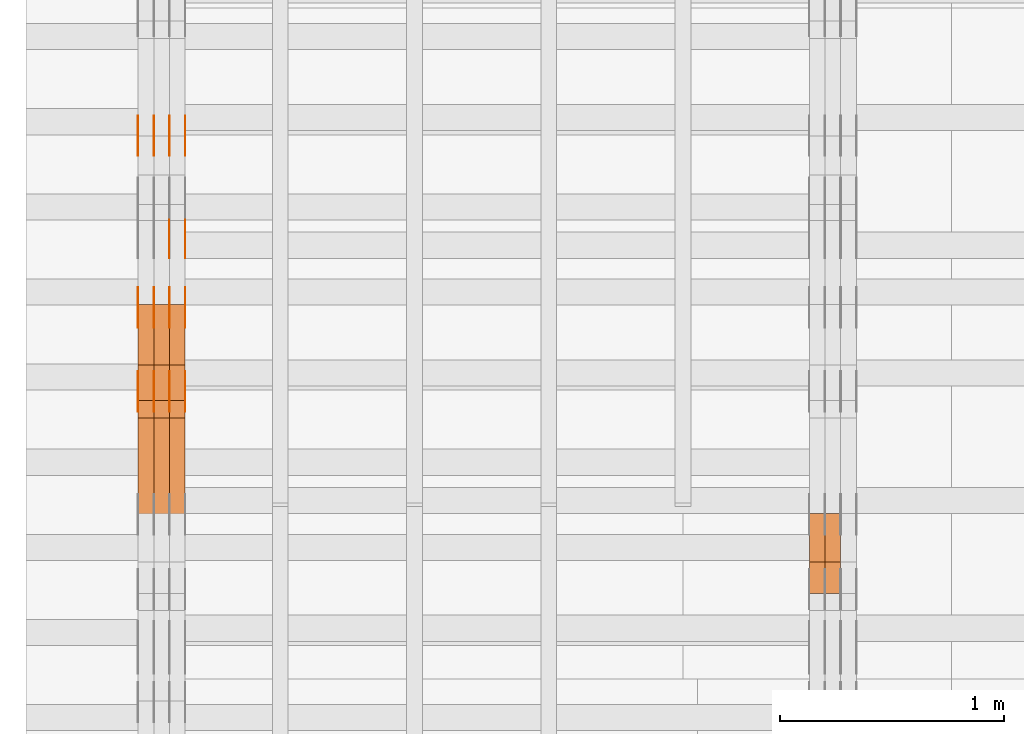
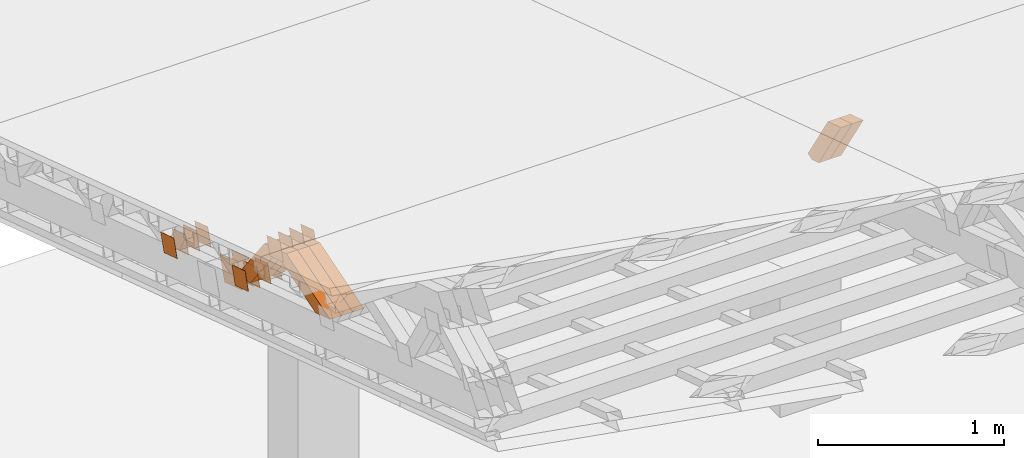
# One storey, part 174 of 385: 28 proxies.
"""IFC2X3 building model written with IfcOpenShell, lengths in millimetres."""

from ifc_helpers import new_model, entity, si_unit, converted_unit, derived_unit, direction, frame, origin, place, context, subcontext, project, spatial, polyline, outline, extrude, source, transform, mapped, material, type_object, type_shapes, element, save


model = new_model("IFC2X3")

# Units and contexts
model_context = context("Model", 3, precision=0.01, world=origin(), true_north=direction((6.12303176911189e-17, 1.0)))
body_context = subcontext(model_context, "Body", "Model", "MODEL_VIEW")
ifc_project = project(units=[si_unit("LENGTHUNIT", "METRE", prefix="MILLI"), si_unit("AREAUNIT", "SQUARE_METRE"), si_unit("VOLUMEUNIT", "CUBIC_METRE"), converted_unit("PLANEANGLEUNIT", "DEGREE", entity("IfcRatioMeasure", 0.0174532925199433), si_unit("PLANEANGLEUNIT", "RADIAN"), dimensions=[0, 0, 0, 0, 0, 0, 0]), si_unit("MASSUNIT", "GRAM", prefix="KILO"), derived_unit("MASSDENSITYUNIT", [(si_unit("MASSUNIT", "GRAM", prefix="KILO"), 1), (si_unit("LENGTHUNIT", "METRE"), -3)]), si_unit("TIMEUNIT", "SECOND"), si_unit("FREQUENCYUNIT", "HERTZ"), si_unit("THERMODYNAMICTEMPERATUREUNIT", "DEGREE_CELSIUS"), derived_unit("THERMALTRANSMITTANCEUNIT", [(si_unit("MASSUNIT", "GRAM", prefix="KILO"), 1), (si_unit("THERMODYNAMICTEMPERATUREUNIT", "KELVIN"), -1), (si_unit("TIMEUNIT", "SECOND"), -3)]), derived_unit("VOLUMETRICFLOWRATEUNIT", [(si_unit("LENGTHUNIT", "METRE"), 3), (si_unit("TIMEUNIT", "SECOND"), -1)]), si_unit("ELECTRICCURRENTUNIT", "AMPERE"), si_unit("ELECTRICVOLTAGEUNIT", "VOLT"), si_unit("POWERUNIT", "WATT"), si_unit("FORCEUNIT", "NEWTON", prefix="KILO"), si_unit("ILLUMINANCEUNIT", "LUX"), si_unit("LUMINOUSFLUXUNIT", "LUMEN"), si_unit("LUMINOUSINTENSITYUNIT", "CANDELA"), derived_unit("USERDEFINED", [(si_unit("MASSUNIT", "GRAM", prefix="KILO"), -1), (si_unit("LENGTHUNIT", "METRE"), -2), (si_unit("TIMEUNIT", "SECOND"), 3), (si_unit("LUMINOUSFLUXUNIT", "LUMEN"), 1)]), derived_unit("LINEARVELOCITYUNIT", [(si_unit("LENGTHUNIT", "METRE"), 1), (si_unit("TIMEUNIT", "SECOND"), -1)]), si_unit("PRESSUREUNIT", "PASCAL"), derived_unit("USERDEFINED", [(si_unit("LENGTHUNIT", "METRE"), -2), (si_unit("MASSUNIT", "GRAM", prefix="KILO"), 1), (si_unit("TIMEUNIT", "SECOND"), -2)])], contexts=[model_context])

# Site, building, storey
site_placement = place(None, origin())
site = spatial("IfcSite", under=ifc_project, at=site_placement, CompositionType="ELEMENT")
building_placement = place(site_placement, origin())
building = spatial("IfcBuilding", under=site, at=building_placement, CompositionType="ELEMENT")
storey_placement = place(building_placement, origin())
storey = spatial("IfcBuildingStorey", under=building, at=storey_placement, Name="Default", CompositionType="ELEMENT", Elevation=0.0)

# Proxies
ifc_material_1 = material(Name="IfcSurfaceStyle #48216")
building_element_proxy_type_1 = type_object("IfcBuildingElementProxyType", Name="T1-W29 48214", PredefinedType="NOTDEFINED", material=ifc_material_1)
shared_shape_1 = source(origin(), body_context, "Body", "SweptSolid", [
    extrude(outline(polyline([(-202.325994317059, -47.5000867467013), (200.714255560873, -47.5000867467013), (187.834128885383, 0.000593513395139059), (130.590899902046, 47.4997899900038), (-316.813290031243, 47.4997899900038), (-202.325994317059, -47.5000867467013)])), frame((200.714255560873, 47.5001935424745, 0.0), z_axis=(0.0, 0.0, 1.0), x_axis=(-1.0, 0.0, 0.0)), (0.0, 0.0, 1.0), 70.0),
])
type_shapes(building_element_proxy_type_1, [shared_shape_1])
proxy_1_placement = place(building_placement, frame((3315.0, 20827.0771193222, 1890.72342063252), z_axis=(-1.0, 0.0, 0.0), x_axis=(0.0, -0.534567451138397, 0.845125813227473)))
element("IfcBuildingElementProxy", 1, at=proxy_1_placement, inside=storey, type_object=building_element_proxy_type_1, material=ifc_material_1, Name="T1-W29", context=body_context, shape_type="MappedRepresentation", body=[
    mapped(shared_shape_1, transform((0.0, 0.0, 0.0), scale=1.0)),
])
ifc_material_2 = material(Name="IfcSurfaceStyle #48150")
building_element_proxy_type_2 = type_object("IfcBuildingElementProxyType", Name="T1-W29 48148", PredefinedType="NOTDEFINED", material=ifc_material_2)
shared_shape_2 = source(origin(), body_context, "Body", "SweptSolid", [
    extrude(outline(polyline([(-202.325994317059, -47.5000867467013), (200.714255560873, -47.5000867467013), (187.834128885383, 0.000593513395139059), (130.590899902046, 47.4997899900038), (-316.813290031243, 47.4997899900038), (-202.325994317059, -47.5000867467013)])), frame((200.714255560873, 47.5001935424745, 0.0), z_axis=(0.0, 0.0, 1.0), x_axis=(-1.0, 0.0, 0.0)), (0.0, 0.0, 1.0), 70.0),
])
type_shapes(building_element_proxy_type_2, [shared_shape_2])
proxy_2_placement = place(building_placement, frame((3245.0, 20827.0771193222, 1890.72342063252), z_axis=(-1.0, 0.0, 0.0), x_axis=(0.0, -0.534567451138397, 0.845125813227473)))
element("IfcBuildingElementProxy", 2, at=proxy_2_placement, inside=storey, type_object=building_element_proxy_type_2, material=ifc_material_2, Name="T1-W29", context=body_context, shape_type="MappedRepresentation", body=[
    mapped(shared_shape_2, transform((0.0, 0.0, 0.0), scale=1.0)),
])
ifc_material_3 = material(Name="IfcSurfaceStyle #34244")
building_element_proxy_type_3 = type_object("IfcBuildingElementProxyType", PredefinedType="NOTDEFINED", material=ifc_material_3)
shared_shape_3 = source(origin(), body_context, "Body", "SweptSolid", [
    extrude(outline(polyline([(-74.9998794200123, -59.999984515643), (74.9998565677174, -59.999984515643), (74.9998794200123, 59.999984515643), (-74.9998565677174, 59.999984515643), (-74.9998794200123, -59.999984515643)])), frame((75.0000769557496, 60.0000596852268, 0.0), z_axis=(0.0, 0.0, 1.0), x_axis=(-1.0, 0.0, 0.0)), (0.0, 0.0, 1.0), 1.3),
])
type_shapes(building_element_proxy_type_3, [shared_shape_3])
proxy_3_placement = place(building_placement, frame((386.299999999986, 22649.3668870864, 1282.62115477841), z_axis=(-1.0, 0.0, 0.0), x_axis=(0.0, -0.951056516295124, 0.309016994375039)))
element("IfcBuildingElementProxy", 3, at=proxy_3_placement, inside=storey, type_object=building_element_proxy_type_3, material=ifc_material_3, context=body_context, shape_type="MappedRepresentation", body=[
    mapped(shared_shape_3, transform((0.0, 0.0, 0.0), scale=1.0)),
])
ifc_material_4 = material(Name="IfcSurfaceStyle #34187")
building_element_proxy_type_4 = type_object("IfcBuildingElementProxyType", PredefinedType="NOTDEFINED", material=ifc_material_4)
shared_shape_4 = source(origin(), body_context, "Body", "SweptSolid", [
    extrude(outline(polyline([(-74.9998794200123, -59.999984515643), (74.9998565677174, -59.999984515643), (74.9998794200123, 59.999984515643), (-74.9998565677174, 59.999984515643), (-74.9998794200123, -59.999984515643)])), frame((75.0000769557496, 60.0000596852268, 0.0), z_axis=(0.0, 0.0, 1.0), x_axis=(-1.0, 0.0, 0.0)), (0.0, 0.0, 1.0), 1.3),
])
type_shapes(building_element_proxy_type_4, [shared_shape_4])
proxy_4_placement = place(building_placement, frame((315.0, 22649.3668870864, 1282.62115477841), z_axis=(-1.0, 0.0, 0.0), x_axis=(0.0, -0.951056516295124, 0.309016994375039)))
element("IfcBuildingElementProxy", 4, at=proxy_4_placement, inside=storey, type_object=building_element_proxy_type_4, material=ifc_material_4, context=body_context, shape_type="MappedRepresentation", body=[
    mapped(shared_shape_4, transform((0.0, 0.0, 0.0), scale=1.0)),
])
ifc_material_5 = material(Name="IfcSurfaceStyle #34130")
building_element_proxy_type_5 = type_object("IfcBuildingElementProxyType", PredefinedType="NOTDEFINED", material=ifc_material_5)
shared_shape_5 = source(origin(), body_context, "Body", "SweptSolid", [
    extrude(outline(polyline([(-74.9998794200123, -59.999984515643), (74.9998565677174, -59.999984515643), (74.9998794200123, 59.999984515643), (-74.9998565677174, 59.999984515643), (-74.9998794200123, -59.999984515643)])), frame((75.0000769557496, 60.0000596852268, 0.0), z_axis=(0.0, 0.0, 1.0), x_axis=(-1.0, 0.0, 0.0)), (0.0, 0.0, 1.0), 1.3),
])
type_shapes(building_element_proxy_type_5, [shared_shape_5])
proxy_5_placement = place(building_placement, frame((316.299999999986, 22649.3668870864, 1282.62115477841), z_axis=(-1.0, 0.0, 0.0), x_axis=(0.0, -0.951056516295124, 0.309016994375039)))
element("IfcBuildingElementProxy", 5, at=proxy_5_placement, inside=storey, type_object=building_element_proxy_type_5, material=ifc_material_5, context=body_context, shape_type="MappedRepresentation", body=[
    mapped(shared_shape_5, transform((0.0, 0.0, 0.0), scale=1.0)),
])
ifc_material_6 = material(Name="IfcSurfaceStyle #34073")
building_element_proxy_type_6 = type_object("IfcBuildingElementProxyType", PredefinedType="NOTDEFINED", material=ifc_material_6)
shared_shape_6 = source(origin(), body_context, "Body", "SweptSolid", [
    extrude(outline(polyline([(-74.9998794200123, -59.999984515643), (74.9998565677174, -59.999984515643), (74.9998794200123, 59.999984515643), (-74.9998565677174, 59.999984515643), (-74.9998794200123, -59.999984515643)])), frame((75.0000769557496, 60.0000596852268, 0.0), z_axis=(0.0, 0.0, 1.0), x_axis=(-1.0, 0.0, 0.0)), (0.0, 0.0, 1.0), 1.29999999999999),
])
type_shapes(building_element_proxy_type_6, [shared_shape_6])
proxy_6_placement = place(building_placement, frame((245.0, 22649.3668870864, 1282.62115477841), z_axis=(-1.0, 0.0, 0.0), x_axis=(0.0, -0.951056516295124, 0.309016994375039)))
element("IfcBuildingElementProxy", 6, at=proxy_6_placement, inside=storey, type_object=building_element_proxy_type_6, material=ifc_material_6, context=body_context, shape_type="MappedRepresentation", body=[
    mapped(shared_shape_6, transform((0.0, 0.0, 0.0), scale=1.0)),
])
ifc_material_7 = material(Name="IfcSurfaceStyle #34016")
building_element_proxy_type_7 = type_object("IfcBuildingElementProxyType", PredefinedType="NOTDEFINED", material=ifc_material_7)
shared_shape_7 = source(origin(), body_context, "Body", "SweptSolid", [
    extrude(outline(polyline([(-74.9998794200123, -59.999984515643), (74.9998565677174, -59.999984515643), (74.9998794200123, 59.999984515643), (-74.9998565677174, 59.999984515643), (-74.9998794200123, -59.999984515643)])), frame((75.0000769557496, 60.0000596852268, 0.0), z_axis=(0.0, 0.0, 1.0), x_axis=(-1.0, 0.0, 0.0)), (0.0, 0.0, 1.0), 1.29999999999999),
])
type_shapes(building_element_proxy_type_7, [shared_shape_7])
proxy_7_placement = place(building_placement, frame((246.299999999986, 22649.3668870864, 1282.62115477841), z_axis=(-1.0, 0.0, 0.0), x_axis=(0.0, -0.951056516295124, 0.309016994375039)))
element("IfcBuildingElementProxy", 7, at=proxy_7_placement, inside=storey, type_object=building_element_proxy_type_7, material=ifc_material_7, context=body_context, shape_type="MappedRepresentation", body=[
    mapped(shared_shape_7, transform((0.0, 0.0, 0.0), scale=1.0)),
])
ifc_material_8 = material(Name="IfcSurfaceStyle #33959")
building_element_proxy_type_8 = type_object("IfcBuildingElementProxyType", PredefinedType="NOTDEFINED", material=ifc_material_8)
shared_shape_8 = source(origin(), body_context, "Body", "SweptSolid", [
    extrude(outline(polyline([(-74.9998794200123, -59.999984515643), (74.9998565677174, -59.999984515643), (74.9998794200123, 59.999984515643), (-74.9998565677174, 59.999984515643), (-74.9998794200123, -59.999984515643)])), frame((75.0000769557496, 60.0000596852268, 0.0), z_axis=(0.0, 0.0, 1.0), x_axis=(-1.0, 0.0, 0.0)), (0.0, 0.0, 1.0), 1.29999999999999),
])
type_shapes(building_element_proxy_type_8, [shared_shape_8])
proxy_8_placement = place(building_placement, frame((175.0, 22649.3668870864, 1282.62115477841), z_axis=(-1.0, 0.0, 0.0), x_axis=(0.0, -0.951056516295124, 0.309016994375039)))
element("IfcBuildingElementProxy", 8, at=proxy_8_placement, inside=storey, type_object=building_element_proxy_type_8, material=ifc_material_8, context=body_context, shape_type="MappedRepresentation", body=[
    mapped(shared_shape_8, transform((0.0, 0.0, 0.0), scale=1.0)),
])
ifc_material_9 = material(Name="IfcSurfaceStyle #33560")
building_element_proxy_type_9 = type_object("IfcBuildingElementProxyType", PredefinedType="NOTDEFINED", material=ifc_material_9)
shared_shape_9 = source(origin(), body_context, "Body", "SweptSolid", [
    extrude(outline(polyline([(-99.9999579276585, -84.0000593595837), (100.000141865112, -84.0000593595837), (99.9999579276589, 84.0000593595837), (-100.000141865112, 84.0000593595837), (-99.9999579276585, -84.0000593595837)])), frame((100.000141865112, 84.0000593595837, 0.0), z_axis=(0.0, 0.0, 1.0), x_axis=(-1.0, 0.0, 0.0)), (0.0, 0.0, 1.0), 1.3),
])
type_shapes(building_element_proxy_type_9, [shared_shape_9])
proxy_9_placement = place(building_placement, frame((386.299999999986, 22239.7296395088, 1287.96775368191), z_axis=(-1.0, 0.0, 0.0), x_axis=(0.0, -0.951056516295124, 0.309016994375039)))
element("IfcBuildingElementProxy", 9, at=proxy_9_placement, inside=storey, type_object=building_element_proxy_type_9, material=ifc_material_9, context=body_context, shape_type="MappedRepresentation", body=[
    mapped(shared_shape_9, transform((0.0, 0.0, 0.0), scale=1.0)),
])
ifc_material_10 = material(Name="IfcSurfaceStyle #33503")
building_element_proxy_type_10 = type_object("IfcBuildingElementProxyType", PredefinedType="NOTDEFINED", material=ifc_material_10)
shared_shape_10 = source(origin(), body_context, "Body", "SweptSolid", [
    extrude(outline(polyline([(-99.9999579276585, -84.0000593595837), (100.000141865112, -84.0000593595837), (99.9999579276589, 84.0000593595837), (-100.000141865112, 84.0000593595837), (-99.9999579276585, -84.0000593595837)])), frame((100.000141865112, 84.0000593595837, 0.0), z_axis=(0.0, 0.0, 1.0), x_axis=(-1.0, 0.0, 0.0)), (0.0, 0.0, 1.0), 1.3),
])
type_shapes(building_element_proxy_type_10, [shared_shape_10])
proxy_10_placement = place(building_placement, frame((315.0, 22239.7296395088, 1287.96775368191), z_axis=(-1.0, 0.0, 0.0), x_axis=(0.0, -0.951056516295124, 0.309016994375039)))
element("IfcBuildingElementProxy", 10, at=proxy_10_placement, inside=storey, type_object=building_element_proxy_type_10, material=ifc_material_10, context=body_context, shape_type="MappedRepresentation", body=[
    mapped(shared_shape_10, transform((0.0, 0.0, 0.0), scale=1.0)),
])
ifc_material_11 = material(Name="IfcSurfaceStyle #31166")
building_element_proxy_type_11 = type_object("IfcBuildingElementProxyType", PredefinedType="NOTDEFINED", material=ifc_material_11)
shared_shape_11 = source(origin(), body_context, "Body", "SweptSolid", [
    extrude(outline(polyline([(-75.0001116115454, -60.0000599592451), (75.0000887592496, -60.0000599592451), (75.0001116115454, 60.0000599592451), (-75.0000887592496, 60.0000599592451), (-75.0001116115454, -60.0000599592451)])), frame((75.0001116115454, 60.0000599592451, 0.0), z_axis=(0.0, 0.0, 1.0), x_axis=(-1.0, 0.0, 0.0)), (0.0, 0.0, 1.0), 1.3),
])
type_shapes(building_element_proxy_type_11, [shared_shape_11])
proxy_11_placement = place(building_placement, frame((386.299999999986, 21881.0815195707, 1532.2522473242), z_axis=(-1.0, 0.0, 0.0), x_axis=(0.0, -0.951056516295124, 0.309016994375039)))
element("IfcBuildingElementProxy", 11, at=proxy_11_placement, inside=storey, type_object=building_element_proxy_type_11, material=ifc_material_11, context=body_context, shape_type="MappedRepresentation", body=[
    mapped(shared_shape_11, transform((0.0, 0.0, 0.0), scale=1.0)),
])
ifc_material_12 = material(Name="IfcSurfaceStyle #31109")
building_element_proxy_type_12 = type_object("IfcBuildingElementProxyType", PredefinedType="NOTDEFINED", material=ifc_material_12)
shared_shape_12 = source(origin(), body_context, "Body", "SweptSolid", [
    extrude(outline(polyline([(-75.0001116115454, -60.0000599592451), (75.0000887592496, -60.0000599592451), (75.0001116115454, 60.0000599592451), (-75.0000887592496, 60.0000599592451), (-75.0001116115454, -60.0000599592451)])), frame((75.0001116115454, 60.0000599592451, 0.0), z_axis=(0.0, 0.0, 1.0), x_axis=(-1.0, 0.0, 0.0)), (0.0, 0.0, 1.0), 1.3),
])
type_shapes(building_element_proxy_type_12, [shared_shape_12])
proxy_12_placement = place(building_placement, frame((315.0, 21881.0815195707, 1532.2522473242), z_axis=(-1.0, 0.0, 0.0), x_axis=(0.0, -0.951056516295124, 0.309016994375039)))
element("IfcBuildingElementProxy", 12, at=proxy_12_placement, inside=storey, type_object=building_element_proxy_type_12, material=ifc_material_12, context=body_context, shape_type="MappedRepresentation", body=[
    mapped(shared_shape_12, transform((0.0, 0.0, 0.0), scale=1.0)),
])
ifc_material_13 = material(Name="IfcSurfaceStyle #31052")
building_element_proxy_type_13 = type_object("IfcBuildingElementProxyType", PredefinedType="NOTDEFINED", material=ifc_material_13)
shared_shape_13 = source(origin(), body_context, "Body", "SweptSolid", [
    extrude(outline(polyline([(-75.0001116115454, -60.0000599592451), (75.0000887592496, -60.0000599592451), (75.0001116115454, 60.0000599592451), (-75.0000887592496, 60.0000599592451), (-75.0001116115454, -60.0000599592451)])), frame((75.0001116115454, 60.0000599592451, 0.0), z_axis=(0.0, 0.0, 1.0), x_axis=(-1.0, 0.0, 0.0)), (0.0, 0.0, 1.0), 1.3),
])
type_shapes(building_element_proxy_type_13, [shared_shape_13])
proxy_13_placement = place(building_placement, frame((316.299999999986, 21881.0815195707, 1532.2522473242), z_axis=(-1.0, 0.0, 0.0), x_axis=(0.0, -0.951056516295124, 0.309016994375039)))
element("IfcBuildingElementProxy", 13, at=proxy_13_placement, inside=storey, type_object=building_element_proxy_type_13, material=ifc_material_13, context=body_context, shape_type="MappedRepresentation", body=[
    mapped(shared_shape_13, transform((0.0, 0.0, 0.0), scale=1.0)),
])
ifc_material_14 = material(Name="IfcSurfaceStyle #30995")
building_element_proxy_type_14 = type_object("IfcBuildingElementProxyType", PredefinedType="NOTDEFINED", material=ifc_material_14)
shared_shape_14 = source(origin(), body_context, "Body", "SweptSolid", [
    extrude(outline(polyline([(-75.0001116115454, -60.0000599592451), (75.0000887592496, -60.0000599592451), (75.0001116115454, 60.0000599592451), (-75.0000887592496, 60.0000599592451), (-75.0001116115454, -60.0000599592451)])), frame((75.0001116115454, 60.0000599592451, 0.0), z_axis=(0.0, 0.0, 1.0), x_axis=(-1.0, 0.0, 0.0)), (0.0, 0.0, 1.0), 1.29999999999999),
])
type_shapes(building_element_proxy_type_14, [shared_shape_14])
proxy_14_placement = place(building_placement, frame((245.0, 21881.0815195707, 1532.2522473242), z_axis=(-1.0, 0.0, 0.0), x_axis=(0.0, -0.951056516295124, 0.309016994375039)))
element("IfcBuildingElementProxy", 14, at=proxy_14_placement, inside=storey, type_object=building_element_proxy_type_14, material=ifc_material_14, context=body_context, shape_type="MappedRepresentation", body=[
    mapped(shared_shape_14, transform((0.0, 0.0, 0.0), scale=1.0)),
])
ifc_material_15 = material(Name="IfcSurfaceStyle #30938")
building_element_proxy_type_15 = type_object("IfcBuildingElementProxyType", PredefinedType="NOTDEFINED", material=ifc_material_15)
shared_shape_15 = source(origin(), body_context, "Body", "SweptSolid", [
    extrude(outline(polyline([(-75.0001116115454, -60.0000599592451), (75.0000887592496, -60.0000599592451), (75.0001116115454, 60.0000599592451), (-75.0000887592496, 60.0000599592451), (-75.0001116115454, -60.0000599592451)])), frame((75.0001116115454, 60.0000599592451, 0.0), z_axis=(0.0, 0.0, 1.0), x_axis=(-1.0, 0.0, 0.0)), (0.0, 0.0, 1.0), 1.29999999999999),
])
type_shapes(building_element_proxy_type_15, [shared_shape_15])
proxy_15_placement = place(building_placement, frame((246.299999999986, 21881.0815195707, 1532.2522473242), z_axis=(-1.0, 0.0, 0.0), x_axis=(0.0, -0.951056516295124, 0.309016994375039)))
element("IfcBuildingElementProxy", 15, at=proxy_15_placement, inside=storey, type_object=building_element_proxy_type_15, material=ifc_material_15, context=body_context, shape_type="MappedRepresentation", body=[
    mapped(shared_shape_15, transform((0.0, 0.0, 0.0), scale=1.0)),
])
ifc_material_16 = material(Name="IfcSurfaceStyle #30881")
building_element_proxy_type_16 = type_object("IfcBuildingElementProxyType", PredefinedType="NOTDEFINED", material=ifc_material_16)
shared_shape_16 = source(origin(), body_context, "Body", "SweptSolid", [
    extrude(outline(polyline([(-75.0001116115454, -60.0000599592451), (75.0000887592496, -60.0000599592451), (75.0001116115454, 60.0000599592451), (-75.0000887592496, 60.0000599592451), (-75.0001116115454, -60.0000599592451)])), frame((75.0001116115454, 60.0000599592451, 0.0), z_axis=(0.0, 0.0, 1.0), x_axis=(-1.0, 0.0, 0.0)), (0.0, 0.0, 1.0), 1.29999999999999),
])
type_shapes(building_element_proxy_type_16, [shared_shape_16])
proxy_16_placement = place(building_placement, frame((175.0, 21881.0815195707, 1532.2522473242), z_axis=(-1.0, 0.0, 0.0), x_axis=(0.0, -0.951056516295124, 0.309016994375039)))
element("IfcBuildingElementProxy", 16, at=proxy_16_placement, inside=storey, type_object=building_element_proxy_type_16, material=ifc_material_16, context=body_context, shape_type="MappedRepresentation", body=[
    mapped(shared_shape_16, transform((0.0, 0.0, 0.0), scale=1.0)),
])
ifc_material_17 = material(Name="IfcSurfaceStyle #25694")
building_element_proxy_type_17 = type_object("IfcBuildingElementProxyType", PredefinedType="NOTDEFINED", material=ifc_material_17)
shared_shape_17 = source(origin(), body_context, "Body", "SweptSolid", [
    extrude(outline(polyline([(-74.9998794200064, -59.9999845156358), (74.9998565677224, -59.9999845156358), (74.9998794200064, 59.9999845156358), (-74.9998565677224, 59.9999845156358), (-74.9998794200064, -59.9999845156358)])), frame((74.9999765995044, 60.0000596852337, 0.0), z_axis=(0.0, 0.0, 1.0), x_axis=(-1.0, 0.0, 0.0)), (0.0, 0.0, 1.0), 1.3),
])
type_shapes(building_element_proxy_type_17, [shared_shape_17])
proxy_17_placement = place(building_placement, frame((386.299999999986, 21505.9776314857, 1954.5332951652), z_axis=(-1.0, 0.0, 0.0), x_axis=(0.0, -0.951056516295154, 0.309016994374948)))
element("IfcBuildingElementProxy", 17, at=proxy_17_placement, inside=storey, type_object=building_element_proxy_type_17, material=ifc_material_17, context=body_context, shape_type="MappedRepresentation", body=[
    mapped(shared_shape_17, transform((0.0, 0.0, 0.0), scale=1.0)),
])
ifc_material_18 = material(Name="IfcSurfaceStyle #25637")
building_element_proxy_type_18 = type_object("IfcBuildingElementProxyType", PredefinedType="NOTDEFINED", material=ifc_material_18)
shared_shape_18 = source(origin(), body_context, "Body", "SweptSolid", [
    extrude(outline(polyline([(-74.9998794200064, -59.9999845156358), (74.9998565677224, -59.9999845156358), (74.9998794200064, 59.9999845156358), (-74.9998565677224, 59.9999845156358), (-74.9998794200064, -59.9999845156358)])), frame((74.9999765995044, 60.0000596852337, 0.0), z_axis=(0.0, 0.0, 1.0), x_axis=(-1.0, 0.0, 0.0)), (0.0, 0.0, 1.0), 1.3),
])
type_shapes(building_element_proxy_type_18, [shared_shape_18])
proxy_18_placement = place(building_placement, frame((315.0, 21505.9776314857, 1954.5332951652), z_axis=(-1.0, 0.0, 0.0), x_axis=(0.0, -0.951056516295154, 0.309016994374948)))
element("IfcBuildingElementProxy", 18, at=proxy_18_placement, inside=storey, type_object=building_element_proxy_type_18, material=ifc_material_18, context=body_context, shape_type="MappedRepresentation", body=[
    mapped(shared_shape_18, transform((0.0, 0.0, 0.0), scale=1.0)),
])
ifc_material_19 = material(Name="IfcSurfaceStyle #25580")
building_element_proxy_type_19 = type_object("IfcBuildingElementProxyType", PredefinedType="NOTDEFINED", material=ifc_material_19)
shared_shape_19 = source(origin(), body_context, "Body", "SweptSolid", [
    extrude(outline(polyline([(-74.9998794200064, -59.9999845156358), (74.9998565677224, -59.9999845156358), (74.9998794200064, 59.9999845156358), (-74.9998565677224, 59.9999845156358), (-74.9998794200064, -59.9999845156358)])), frame((74.9999765995044, 60.0000596852337, 0.0), z_axis=(0.0, 0.0, 1.0), x_axis=(-1.0, 0.0, 0.0)), (0.0, 0.0, 1.0), 1.3),
])
type_shapes(building_element_proxy_type_19, [shared_shape_19])
proxy_19_placement = place(building_placement, frame((316.299999999986, 21505.9776314857, 1954.5332951652), z_axis=(-1.0, 0.0, 0.0), x_axis=(0.0, -0.951056516295154, 0.309016994374948)))
element("IfcBuildingElementProxy", 19, at=proxy_19_placement, inside=storey, type_object=building_element_proxy_type_19, material=ifc_material_19, context=body_context, shape_type="MappedRepresentation", body=[
    mapped(shared_shape_19, transform((0.0, 0.0, 0.0), scale=1.0)),
])
ifc_material_20 = material(Name="IfcSurfaceStyle #25523")
building_element_proxy_type_20 = type_object("IfcBuildingElementProxyType", PredefinedType="NOTDEFINED", material=ifc_material_20)
shared_shape_20 = source(origin(), body_context, "Body", "SweptSolid", [
    extrude(outline(polyline([(-74.9998794200064, -59.9999845156358), (74.9998565677224, -59.9999845156358), (74.9998794200064, 59.9999845156358), (-74.9998565677224, 59.9999845156358), (-74.9998794200064, -59.9999845156358)])), frame((74.9999765995044, 60.0000596852337, 0.0), z_axis=(0.0, 0.0, 1.0), x_axis=(-1.0, 0.0, 0.0)), (0.0, 0.0, 1.0), 1.29999999999999),
])
type_shapes(building_element_proxy_type_20, [shared_shape_20])
proxy_20_placement = place(building_placement, frame((245.0, 21505.9776314857, 1954.5332951652), z_axis=(-1.0, 0.0, 0.0), x_axis=(0.0, -0.951056516295154, 0.309016994374948)))
element("IfcBuildingElementProxy", 20, at=proxy_20_placement, inside=storey, type_object=building_element_proxy_type_20, material=ifc_material_20, context=body_context, shape_type="MappedRepresentation", body=[
    mapped(shared_shape_20, transform((0.0, 0.0, 0.0), scale=1.0)),
])
ifc_material_21 = material(Name="IfcSurfaceStyle #25466")
building_element_proxy_type_21 = type_object("IfcBuildingElementProxyType", PredefinedType="NOTDEFINED", material=ifc_material_21)
shared_shape_21 = source(origin(), body_context, "Body", "SweptSolid", [
    extrude(outline(polyline([(-74.9998794200064, -59.9999845156358), (74.9998565677224, -59.9999845156358), (74.9998794200064, 59.9999845156358), (-74.9998565677224, 59.9999845156358), (-74.9998794200064, -59.9999845156358)])), frame((74.9999765995044, 60.0000596852337, 0.0), z_axis=(0.0, 0.0, 1.0), x_axis=(-1.0, 0.0, 0.0)), (0.0, 0.0, 1.0), 1.29999999999999),
])
type_shapes(building_element_proxy_type_21, [shared_shape_21])
proxy_21_placement = place(building_placement, frame((246.299999999986, 21505.9776314857, 1954.5332951652), z_axis=(-1.0, 0.0, 0.0), x_axis=(0.0, -0.951056516295154, 0.309016994374948)))
element("IfcBuildingElementProxy", 21, at=proxy_21_placement, inside=storey, type_object=building_element_proxy_type_21, material=ifc_material_21, context=body_context, shape_type="MappedRepresentation", body=[
    mapped(shared_shape_21, transform((0.0, 0.0, 0.0), scale=1.0)),
])
ifc_material_22 = material(Name="IfcSurfaceStyle #25409")
building_element_proxy_type_22 = type_object("IfcBuildingElementProxyType", PredefinedType="NOTDEFINED", material=ifc_material_22)
shared_shape_22 = source(origin(), body_context, "Body", "SweptSolid", [
    extrude(outline(polyline([(-74.9998794200064, -59.9999845156358), (74.9998565677224, -59.9999845156358), (74.9998794200064, 59.9999845156358), (-74.9998565677224, 59.9999845156358), (-74.9998794200064, -59.9999845156358)])), frame((74.9999765995044, 60.0000596852337, 0.0), z_axis=(0.0, 0.0, 1.0), x_axis=(-1.0, 0.0, 0.0)), (0.0, 0.0, 1.0), 1.29999999999999),
])
type_shapes(building_element_proxy_type_22, [shared_shape_22])
proxy_22_placement = place(building_placement, frame((175.0, 21505.9776314857, 1954.5332951652), z_axis=(-1.0, 0.0, 0.0), x_axis=(0.0, -0.951056516295154, 0.309016994374948)))
element("IfcBuildingElementProxy", 22, at=proxy_22_placement, inside=storey, type_object=building_element_proxy_type_22, material=ifc_material_22, context=body_context, shape_type="MappedRepresentation", body=[
    mapped(shared_shape_22, transform((0.0, 0.0, 0.0), scale=1.0)),
])
ifc_material_23 = material(Name="IfcSurfaceStyle #13454")
building_element_proxy_type_23 = type_object("IfcBuildingElementProxyType", Name="T1-W20 13452", PredefinedType="NOTDEFINED", material=ifc_material_23)
shared_shape_23 = source(origin(), body_context, "Body", "SweptSolid", [
    extrude(outline(polyline([(-355.264945969921, -47.5000317999193), (141.064821099313, -47.5000317999193), (208.541978467889, 8.19311626391928e-05), (225.96877763549, 47.499990834338), (-220.31063123277, 47.4999908343379), (-355.264945969921, -47.5000317999193)])), frame((225.968921063481, 47.5000683592689, 0.0), z_axis=(0.0, 0.0, 1.0), x_axis=(-1.0, 0.0, 0.0)), (0.0, 0.0, 1.0), 70.0),
])
type_shapes(building_element_proxy_type_23, [shared_shape_23])
proxy_23_placement = place(building_placement, frame((385.0, 21443.7472302196, 2007.54830804072), z_axis=(-1.0, 0.0, 0.0), x_axis=(0.0, -0.95556995517236, -0.29476441571515)))
element("IfcBuildingElementProxy", 23, at=proxy_23_placement, inside=storey, type_object=building_element_proxy_type_23, material=ifc_material_23, Name="T1-W20", context=body_context, shape_type="MappedRepresentation", body=[
    mapped(shared_shape_23, transform((0.0, 0.0, 0.0), scale=1.0)),
])
ifc_material_24 = material(Name="IfcSurfaceStyle #13388")
building_element_proxy_type_24 = type_object("IfcBuildingElementProxyType", Name="T1-W20 13386", PredefinedType="NOTDEFINED", material=ifc_material_24)
shared_shape_24 = source(origin(), body_context, "Body", "SweptSolid", [
    extrude(outline(polyline([(-355.264945969921, -47.5000317999193), (141.064821099313, -47.5000317999193), (208.541978467889, 8.19311626391928e-05), (225.96877763549, 47.499990834338), (-220.31063123277, 47.4999908343379), (-355.264945969921, -47.5000317999193)])), frame((225.968921063481, 47.5000683592689, 0.0), z_axis=(0.0, 0.0, 1.0), x_axis=(-1.0, 0.0, 0.0)), (0.0, 0.0, 1.0), 70.0),
])
type_shapes(building_element_proxy_type_24, [shared_shape_24])
proxy_24_placement = place(building_placement, frame((315.0, 21443.7472302196, 2007.54830804072), z_axis=(-1.0, 0.0, 0.0), x_axis=(0.0, -0.95556995517236, -0.29476441571515)))
element("IfcBuildingElementProxy", 24, at=proxy_24_placement, inside=storey, type_object=building_element_proxy_type_24, material=ifc_material_24, Name="T1-W20", context=body_context, shape_type="MappedRepresentation", body=[
    mapped(shared_shape_24, transform((0.0, 0.0, 0.0), scale=1.0)),
])
ifc_material_25 = material(Name="IfcSurfaceStyle #13322")
building_element_proxy_type_25 = type_object("IfcBuildingElementProxyType", Name="T1-W20 13320", PredefinedType="NOTDEFINED", material=ifc_material_25)
shared_shape_25 = source(origin(), body_context, "Body", "SweptSolid", [
    extrude(outline(polyline([(-355.264945969921, -47.5000317999193), (141.064821099313, -47.5000317999193), (208.541978467889, 8.19311626391928e-05), (225.96877763549, 47.499990834338), (-220.31063123277, 47.4999908343379), (-355.264945969921, -47.5000317999193)])), frame((225.968921063481, 47.5000683592689, 0.0), z_axis=(0.0, 0.0, 1.0), x_axis=(-1.0, 0.0, 0.0)), (0.0, 0.0, 1.0), 70.0),
])
type_shapes(building_element_proxy_type_25, [shared_shape_25])
proxy_25_placement = place(building_placement, frame((245.0, 21443.7472302196, 2007.54830804072), z_axis=(-1.0, 0.0, 0.0), x_axis=(0.0, -0.95556995517236, -0.29476441571515)))
element("IfcBuildingElementProxy", 25, at=proxy_25_placement, inside=storey, type_object=building_element_proxy_type_25, material=ifc_material_25, Name="T1-W20", context=body_context, shape_type="MappedRepresentation", body=[
    mapped(shared_shape_25, transform((0.0, 0.0, 0.0), scale=1.0)),
])
ifc_material_26 = material(Name="IfcSurfaceStyle #13058")
building_element_proxy_type_26 = type_object("IfcBuildingElementProxyType", Name="T1-W18 13056", PredefinedType="NOTDEFINED", material=ifc_material_26)
shared_shape_26 = source(origin(), body_context, "Body", "SweptSolid", [
    extrude(outline(polyline([(-221.504996322134, -47.4999929258616), (225.406467948779, -47.4999929258616), (211.663832468686, -0.000107703153482008), (143.08905281687, 47.5000467774384), (-358.6543569122, 47.5000467774384), (-221.504996322134, -47.4999929258616)])), frame((225.406576158364, 47.5000467774384, 0.0), z_axis=(0.0, 0.0, 1.0), x_axis=(-1.0, 0.0, 0.0)), (0.0, 0.0, 1.0), 70.0),
])
type_shapes(building_element_proxy_type_26, [shared_shape_26])
proxy_26_placement = place(building_placement, frame((385.0, 21766.9513837803, 1583.13813361817), z_axis=(-1.0, 0.0, 0.0), x_axis=(0.0, -0.605858491298265, 0.795572428206126)))
element("IfcBuildingElementProxy", 26, at=proxy_26_placement, inside=storey, type_object=building_element_proxy_type_26, material=ifc_material_26, Name="T1-W18", context=body_context, shape_type="MappedRepresentation", body=[
    mapped(shared_shape_26, transform((0.0, 0.0, 0.0), scale=1.0)),
])
ifc_material_27 = material(Name="IfcSurfaceStyle #12992")
building_element_proxy_type_27 = type_object("IfcBuildingElementProxyType", Name="T1-W18 12990", PredefinedType="NOTDEFINED", material=ifc_material_27)
shared_shape_27 = source(origin(), body_context, "Body", "SweptSolid", [
    extrude(outline(polyline([(-221.504996322134, -47.4999929258616), (225.406467948779, -47.4999929258616), (211.663832468686, -0.000107703153482008), (143.08905281687, 47.5000467774384), (-358.6543569122, 47.5000467774384), (-221.504996322134, -47.4999929258616)])), frame((225.406576158364, 47.5000467774384, 0.0), z_axis=(0.0, 0.0, 1.0), x_axis=(-1.0, 0.0, 0.0)), (0.0, 0.0, 1.0), 70.0),
])
type_shapes(building_element_proxy_type_27, [shared_shape_27])
proxy_27_placement = place(building_placement, frame((315.0, 21766.9513837803, 1583.13813361817), z_axis=(-1.0, 0.0, 0.0), x_axis=(0.0, -0.605858491298265, 0.795572428206126)))
element("IfcBuildingElementProxy", 27, at=proxy_27_placement, inside=storey, type_object=building_element_proxy_type_27, material=ifc_material_27, Name="T1-W18", context=body_context, shape_type="MappedRepresentation", body=[
    mapped(shared_shape_27, transform((0.0, 0.0, 0.0), scale=1.0)),
])
ifc_material_28 = material(Name="IfcSurfaceStyle #12926")
building_element_proxy_type_28 = type_object("IfcBuildingElementProxyType", Name="T1-W18 12924", PredefinedType="NOTDEFINED", material=ifc_material_28)
shared_shape_28 = source(origin(), body_context, "Body", "SweptSolid", [
    extrude(outline(polyline([(-221.504996322134, -47.4999929258616), (225.406467948779, -47.4999929258616), (211.663832468686, -0.000107703153482008), (143.08905281687, 47.5000467774384), (-358.6543569122, 47.5000467774384), (-221.504996322134, -47.4999929258616)])), frame((225.406576158364, 47.5000467774384, 0.0), z_axis=(0.0, 0.0, 1.0), x_axis=(-1.0, 0.0, 0.0)), (0.0, 0.0, 1.0), 70.0),
])
type_shapes(building_element_proxy_type_28, [shared_shape_28])
proxy_28_placement = place(building_placement, frame((245.0, 21766.9513837803, 1583.13813361817), z_axis=(-1.0, 0.0, 0.0), x_axis=(0.0, -0.605858491298265, 0.795572428206126)))
element("IfcBuildingElementProxy", 28, at=proxy_28_placement, inside=storey, type_object=building_element_proxy_type_28, material=ifc_material_28, Name="T1-W18", context=body_context, shape_type="MappedRepresentation", body=[
    mapped(shared_shape_28, transform((0.0, 0.0, 0.0), scale=1.0)),
])

save(model, "model.ifc")
